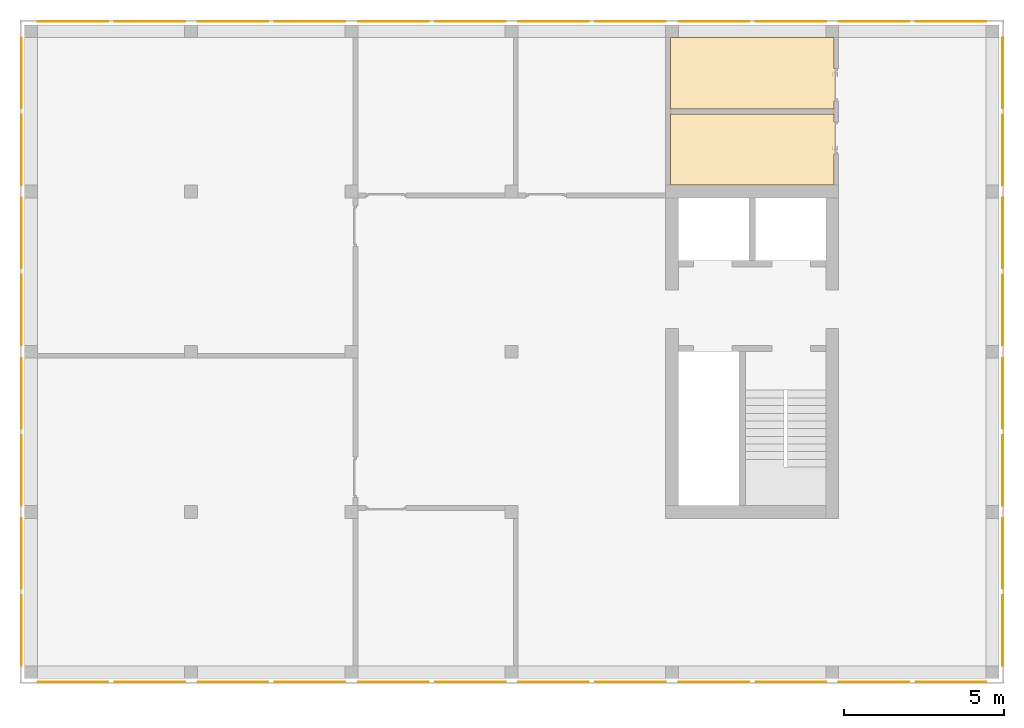
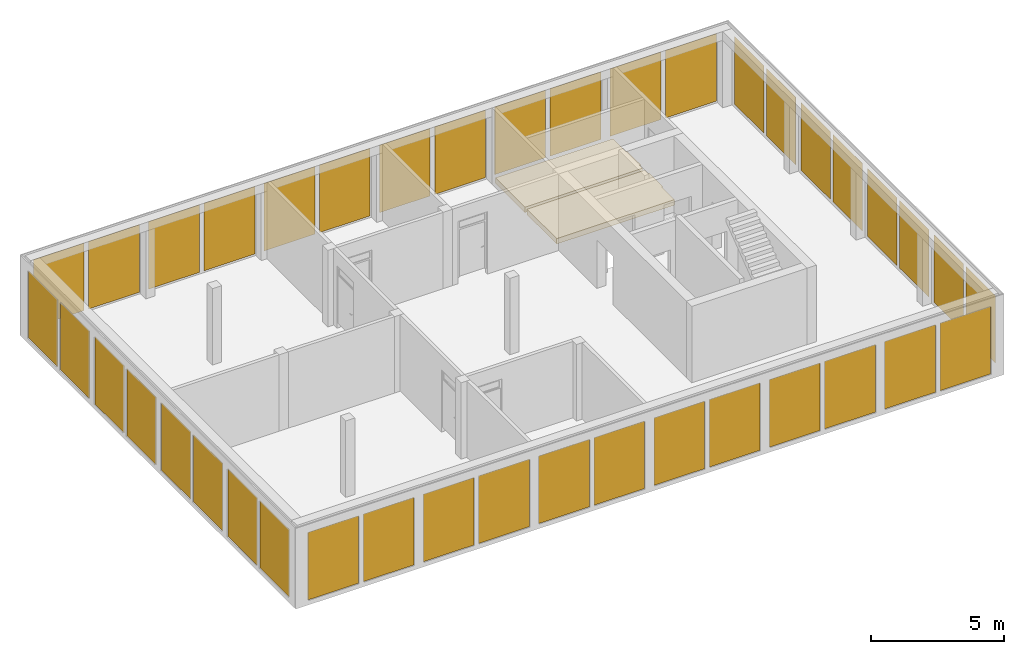
# One storey, part 5 of 6: 40 curtain walls, 2 coverings.
"""IFC2X3 building model written with IfcOpenShell, lengths in metres."""

from ifc_helpers import new_model, entity, si_unit, converted_unit, frame, frame_2d, origin, place, context, subcontext, project, spatial, rectangle, extrude, faceted_brep, material, layer, layer_set, layer_usage, element, save


model = new_model("IFC2X3")

# Units and contexts
model_context = context("Model", 3, precision=1e-05, world=origin())
body_context = subcontext(model_context, "Body", "Model", "MODEL_VIEW")
ifc_project = project(units=[si_unit("LENGTHUNIT", "METRE"), si_unit("AREAUNIT", "SQUARE_METRE"), si_unit("VOLUMEUNIT", "CUBIC_METRE"), si_unit("MASSUNIT", "GRAM", prefix="KILO"), converted_unit("PLANEANGLEUNIT", "DEGREE", entity("IfcPlaneAngleMeasure", 0.0174532925199433), si_unit("PLANEANGLEUNIT", "RADIAN"), dimensions=[0, 0, 0, 0, 0, 0, 0])], contexts=[model_context])

# Site, building, storey
site_placement = place(None, origin())
site = spatial("IfcSite", under=ifc_project, at=site_placement, CompositionType="ELEMENT")
building_placement = place(site_placement, origin())
building = spatial("IfcBuilding", under=site, at=building_placement, CompositionType="ELEMENT")
storey_placement = place(building_placement, frame((0.0, 0.0, 8.6)))
storey = spatial("IfcBuildingStorey", under=building, at=storey_placement, Name="2. Obergeschoss", CompositionType="ELEMENT", Elevation=8.6)

# Curtain walls
ifc_material_1 = material(Name="VSG")
curtain_wall_1_placement = place(storey_placement, frame((30.5106692939828, 0.400000000000018, 0.0)))
element("IfcCurtainWall", 1, at=curtain_wall_1_placement, inside=storey, material=ifc_material_1, Name="standard", context=body_context, shape_type="Brep", body=[
    faceted_brep([(0.0, 0.0, 0.0), (0.0, 0.0, 3.1), (0.005, 0.0, 3.1), (0.005, 0.0, 0.0), (0.005, 2.2, 3.1), (0.005, 2.2, 0.0), (0.0, 2.2, 3.1), (0.0, 2.2, 0.0)], [[[0, 1, 2, 3]], [[3, 2, 4, 5]], [[5, 4, 6, 7]], [[7, 6, 1, 0]], [[6, 4, 2, 1]], [[0, 3, 5, 7]]], orient=[[False], [False], [False], [False], [False], [False]]),
])
ifc_material_2 = material(Name="VSG")
curtain_wall_2_placement = place(storey_placement, frame((-0.0943307060172242, 17.8, 0.0)))
element("IfcCurtainWall", 2, at=curtain_wall_2_placement, inside=storey, material=ifc_material_2, Name="standard", context=body_context, shape_type="Brep", body=[
    faceted_brep([(0.005, -3.63797880709171e-15, 0.0), (0.0, -3.63797880709171e-15, 0.0), (0.0, -3.63797880709171e-15, 3.1), (0.005, -3.63797880709171e-15, 3.1), (0.0, 2.2, 0.0), (0.0, 2.2, 3.1), (0.005, 2.2, 0.0), (0.005, 2.2, 3.1)], [[[0, 1, 2, 3]], [[1, 4, 5, 2]], [[4, 6, 7, 5]], [[6, 0, 3, 7]], [[7, 3, 2, 5]], [[0, 6, 4, 1]]], orient=[[False], [False], [False], [False], [False], [False]]),
])
ifc_material_3 = material(Name="VSG")
curtain_wall_3_placement = place(storey_placement, frame((-0.0943307060172219, 15.4, 0.0)))
element("IfcCurtainWall", 3, at=curtain_wall_3_placement, inside=storey, material=ifc_material_3, Name="standard", context=body_context, shape_type="Brep", body=[
    faceted_brep([(0.005, -1.81898940354586e-15, 0.0), (0.0, -1.81898940354586e-15, 0.0), (0.0, -1.81898940354586e-15, 3.1), (0.005, -1.81898940354586e-15, 3.1), (0.0, 2.2, 0.0), (0.0, 2.2, 3.1), (0.005, 2.2, 0.0), (0.005, 2.2, 3.1)], [[[0, 1, 2, 3]], [[1, 4, 5, 2]], [[4, 6, 7, 5]], [[6, 0, 3, 7]], [[7, 3, 2, 5]], [[0, 6, 4, 1]]], orient=[[False], [False], [False], [False], [False], [False]]),
])
ifc_material_4 = material(Name="VSG")
curtain_wall_4_placement = place(storey_placement, frame((-0.0943307060172236, 12.8, 0.0)))
element("IfcCurtainWall", 4, at=curtain_wall_4_placement, inside=storey, material=ifc_material_4, Name="standard", context=body_context, shape_type="Brep", body=[
    faceted_brep([(0.005, 0.0, 0.0), (0.0, 0.0, 0.0), (0.0, 0.0, 3.1), (0.005, 0.0, 3.1), (0.0, 2.2, 0.0), (0.0, 2.2, 3.1), (0.005, 2.2, 0.0), (0.005, 2.2, 3.1)], [[[0, 1, 2, 3]], [[1, 4, 5, 2]], [[4, 6, 7, 5]], [[6, 0, 3, 7]], [[7, 3, 2, 5]], [[0, 6, 4, 1]]], orient=[[False], [False], [False], [False], [False], [False]]),
])
ifc_material_5 = material(Name="VSG")
curtain_wall_5_placement = place(storey_placement, frame((-0.0943307060172219, 10.4, 0.0)))
element("IfcCurtainWall", 5, at=curtain_wall_5_placement, inside=storey, material=ifc_material_5, Name="standard", context=body_context, shape_type="Brep", body=[
    faceted_brep([(0.005, 0.0, 0.0), (0.0, 0.0, 0.0), (0.0, 0.0, 3.1), (0.005, 0.0, 3.1), (0.0, 2.2, 0.0), (0.0, 2.2, 3.1), (0.005, 2.2, 0.0), (0.005, 2.2, 3.1)], [[[0, 1, 2, 3]], [[1, 4, 5, 2]], [[4, 6, 7, 5]], [[6, 0, 3, 7]], [[7, 3, 2, 5]], [[0, 6, 4, 1]]], orient=[[False], [False], [False], [False], [False], [False]]),
])
ifc_material_6 = material(Name="VSG")
curtain_wall_6_placement = place(storey_placement, frame((-0.0943307060172231, 7.80000000000001, 0.0)))
element("IfcCurtainWall", 6, at=curtain_wall_6_placement, inside=storey, material=ifc_material_6, Name="standard", context=body_context, shape_type="Brep", body=[
    faceted_brep([(0.005, 0.0, 0.0), (0.0, 0.0, 0.0), (0.0, 0.0, 3.1), (0.005, 0.0, 3.1), (0.0, 2.2, 0.0), (0.0, 2.2, 3.1), (0.005, 2.2, 0.0), (0.005, 2.2, 3.1)], [[[0, 1, 2, 3]], [[1, 4, 5, 2]], [[4, 6, 7, 5]], [[6, 0, 3, 7]], [[7, 3, 2, 5]], [[0, 6, 4, 1]]], orient=[[False], [False], [False], [False], [False], [False]]),
])
ifc_material_7 = material(Name="VSG")
curtain_wall_7_placement = place(storey_placement, frame((-0.0943307060172219, 5.40000000000002, 0.0)))
element("IfcCurtainWall", 7, at=curtain_wall_7_placement, inside=storey, material=ifc_material_7, Name="standard", context=body_context, shape_type="Brep", body=[
    faceted_brep([(0.005, 0.0, 0.0), (0.0, 0.0, 0.0), (0.0, 0.0, 3.1), (0.005, 0.0, 3.1), (0.0, 2.2, 0.0), (0.0, 2.2, 3.1), (0.005, 2.2, 0.0), (0.005, 2.2, 3.1)], [[[0, 1, 2, 3]], [[1, 4, 5, 2]], [[4, 6, 7, 5]], [[6, 0, 3, 7]], [[7, 3, 2, 5]], [[0, 6, 4, 1]]], orient=[[False], [False], [False], [False], [False], [False]]),
])
ifc_material_8 = material(Name="VSG")
curtain_wall_8_placement = place(storey_placement, frame((-0.0943307060172225, 2.80000000000001, 0.0)))
element("IfcCurtainWall", 8, at=curtain_wall_8_placement, inside=storey, material=ifc_material_8, Name="standard", context=body_context, shape_type="Brep", body=[
    faceted_brep([(0.005, 0.0, 0.0), (0.0, 0.0, 0.0), (0.0, 0.0, 3.1), (0.005, 0.0, 3.1), (0.0, 2.2, 0.0), (0.0, 2.2, 3.1), (0.005, 2.2, 0.0), (0.005, 2.2, 3.1)], [[[0, 1, 2, 3]], [[1, 4, 5, 2]], [[4, 6, 7, 5]], [[6, 0, 3, 7]], [[7, 3, 2, 5]], [[0, 6, 4, 1]]], orient=[[False], [False], [False], [False], [False], [False]]),
])
ifc_material_9 = material(Name="VSG")
curtain_wall_9_placement = place(storey_placement, frame((-0.0943307060172219, 0.400000000000018, 0.0)))
element("IfcCurtainWall", 9, at=curtain_wall_9_placement, inside=storey, material=ifc_material_9, Name="standard", context=body_context, shape_type="Brep", body=[
    faceted_brep([(0.005, 0.0, 0.0), (0.0, 0.0, 0.0), (0.0, 0.0, 3.1), (0.005, 0.0, 3.1), (0.0, 2.2, 0.0), (0.0, 2.2, 3.1), (0.005, 2.2, 0.0), (0.005, 2.2, 3.1)], [[[0, 1, 2, 3]], [[1, 4, 5, 2]], [[4, 6, 7, 5]], [[6, 0, 3, 7]], [[7, 3, 2, 5]], [[0, 6, 4, 1]]], orient=[[False], [False], [False], [False], [False], [False]]),
])
ifc_material_10 = material(Name="VSG")
curtain_wall_10_placement = place(storey_placement, frame((0.410669293982781, -0.105, 0.0)))
element("IfcCurtainWall", 10, at=curtain_wall_10_placement, inside=storey, material=ifc_material_10, Name="standard", context=body_context, shape_type="Brep", body=[
    faceted_brep([(2.2, 0.00500000000000001, 0.0), (2.2, 1.4210854715202e-17, 0.0), (2.2, 1.4210854715202e-17, 3.1), (2.2, 0.00500000000000001, 3.1), (0.0, 2.8421709430404e-16, 0.0), (0.0, 2.8421709430404e-16, 3.1), (0.0, 0.00500000000000028, 0.0), (0.0, 0.00500000000000028, 3.1)], [[[0, 1, 2, 3]], [[1, 4, 5, 2]], [[4, 6, 7, 5]], [[6, 0, 3, 7]], [[7, 3, 2, 5]], [[0, 6, 4, 1]]], orient=[[False], [False], [False], [False], [False], [False]]),
])
ifc_material_11 = material(Name="VSG")
curtain_wall_11_placement = place(storey_placement, frame((2.81066929398278, -0.105, 0.0)))
element("IfcCurtainWall", 11, at=curtain_wall_11_placement, inside=storey, material=ifc_material_11, Name="standard", context=body_context, shape_type="Brep", body=[
    faceted_brep([(2.2, 0.00500000000000001, 0.0), (2.2, 1.4210854715202e-17, 0.0), (2.2, 1.4210854715202e-17, 3.1), (2.2, 0.00500000000000001, 3.1), (0.0, 2.8421709430404e-16, 0.0), (0.0, 2.8421709430404e-16, 3.1), (0.0, 0.00500000000000028, 0.0), (0.0, 0.00500000000000028, 3.1)], [[[0, 1, 2, 3]], [[1, 4, 5, 2]], [[4, 6, 7, 5]], [[6, 0, 3, 7]], [[7, 3, 2, 5]], [[0, 6, 4, 1]]], orient=[[False], [False], [False], [False], [False], [False]]),
])
ifc_material_12 = material(Name="VSG")
curtain_wall_12_placement = place(storey_placement, frame((5.41066929398277, -0.105, 0.0)))
element("IfcCurtainWall", 12, at=curtain_wall_12_placement, inside=storey, material=ifc_material_12, Name="standard", context=body_context, shape_type="Brep", body=[
    faceted_brep([(2.2, 0.00500000000000001, 0.0), (2.2, 1.4210854715202e-17, 0.0), (2.2, 1.4210854715202e-17, 3.1), (2.2, 0.00500000000000001, 3.1), (0.0, 2.8421709430404e-16, 0.0), (0.0, 2.8421709430404e-16, 3.1), (0.0, 0.00500000000000028, 0.0), (0.0, 0.00500000000000028, 3.1)], [[[0, 1, 2, 3]], [[1, 4, 5, 2]], [[4, 6, 7, 5]], [[6, 0, 3, 7]], [[7, 3, 2, 5]], [[0, 6, 4, 1]]], orient=[[False], [False], [False], [False], [False], [False]]),
])
ifc_material_13 = material(Name="VSG")
curtain_wall_13_placement = place(storey_placement, frame((7.81066929398278, -0.105, 0.0)))
element("IfcCurtainWall", 13, at=curtain_wall_13_placement, inside=storey, material=ifc_material_13, Name="standard", context=body_context, shape_type="Brep", body=[
    faceted_brep([(2.2, 0.00500000000000001, 0.0), (2.2, 1.4210854715202e-17, 0.0), (2.2, 1.4210854715202e-17, 3.1), (2.2, 0.00500000000000001, 3.1), (0.0, 2.8421709430404e-16, 0.0), (0.0, 2.8421709430404e-16, 3.1), (0.0, 0.00500000000000028, 0.0), (0.0, 0.00500000000000028, 3.1)], [[[0, 1, 2, 3]], [[1, 4, 5, 2]], [[4, 6, 7, 5]], [[6, 0, 3, 7]], [[7, 3, 2, 5]], [[0, 6, 4, 1]]], orient=[[False], [False], [False], [False], [False], [False]]),
])
ifc_material_14 = material(Name="VSG")
curtain_wall_14_placement = place(storey_placement, frame((10.4106692939828, -0.105, 0.0)))
element("IfcCurtainWall", 14, at=curtain_wall_14_placement, inside=storey, material=ifc_material_14, Name="standard", context=body_context, shape_type="Brep", body=[
    faceted_brep([(2.2, 0.00500000000000001, 0.0), (2.2, 1.4210854715202e-17, 0.0), (2.2, 1.4210854715202e-17, 3.1), (2.2, 0.00500000000000001, 3.1), (0.0, 2.8421709430404e-16, 0.0), (0.0, 2.8421709430404e-16, 3.1), (0.0, 0.00500000000000028, 0.0), (0.0, 0.00500000000000028, 3.1)], [[[0, 1, 2, 3]], [[1, 4, 5, 2]], [[4, 6, 7, 5]], [[6, 0, 3, 7]], [[7, 3, 2, 5]], [[0, 6, 4, 1]]], orient=[[False], [False], [False], [False], [False], [False]]),
])
ifc_material_15 = material(Name="VSG")
curtain_wall_15_placement = place(storey_placement, frame((12.8106692939828, -0.105, 0.0)))
element("IfcCurtainWall", 15, at=curtain_wall_15_placement, inside=storey, material=ifc_material_15, Name="standard", context=body_context, shape_type="Brep", body=[
    faceted_brep([(2.2, 0.00500000000000001, 0.0), (2.2, 1.4210854715202e-17, 0.0), (2.2, 1.4210854715202e-17, 3.1), (2.2, 0.00500000000000001, 3.1), (0.0, 2.8421709430404e-16, 0.0), (0.0, 2.8421709430404e-16, 3.1), (0.0, 0.00500000000000028, 0.0), (0.0, 0.00500000000000028, 3.1)], [[[0, 1, 2, 3]], [[1, 4, 5, 2]], [[4, 6, 7, 5]], [[6, 0, 3, 7]], [[7, 3, 2, 5]], [[0, 6, 4, 1]]], orient=[[False], [False], [False], [False], [False], [False]]),
])
ifc_material_16 = material(Name="VSG")
curtain_wall_16_placement = place(storey_placement, frame((15.4106692939828, -0.105, 0.0)))
element("IfcCurtainWall", 16, at=curtain_wall_16_placement, inside=storey, material=ifc_material_16, Name="standard", context=body_context, shape_type="Brep", body=[
    faceted_brep([(2.20000000000001, 0.00500000000000001, 0.0), (2.20000000000001, 1.4210854715202e-17, 0.0), (2.20000000000001, 1.4210854715202e-17, 3.1), (2.20000000000001, 0.00500000000000001, 3.1), (1.81898940354586e-15, 2.8421709430404e-16, 0.0), (1.81898940354586e-15, 2.8421709430404e-16, 3.1), (1.81898940354586e-15, 0.00500000000000028, 0.0), (1.81898940354586e-15, 0.00500000000000028, 3.1)], [[[0, 1, 2, 3]], [[1, 4, 5, 2]], [[4, 6, 7, 5]], [[6, 0, 3, 7]], [[7, 3, 2, 5]], [[0, 6, 4, 1]]], orient=[[False], [False], [False], [False], [False], [False]]),
])
ifc_material_17 = material(Name="VSG")
curtain_wall_17_placement = place(storey_placement, frame((17.8106692939828, -0.105, 0.0)))
element("IfcCurtainWall", 17, at=curtain_wall_17_placement, inside=storey, material=ifc_material_17, Name="standard", context=body_context, shape_type="Brep", body=[
    faceted_brep([(2.2, 0.00500000000000001, 0.0), (2.2, 1.4210854715202e-17, 0.0), (2.2, 1.4210854715202e-17, 3.1), (2.2, 0.00500000000000001, 3.1), (0.0, 2.8421709430404e-16, 0.0), (0.0, 2.8421709430404e-16, 3.1), (0.0, 0.00500000000000028, 0.0), (0.0, 0.00500000000000028, 3.1)], [[[0, 1, 2, 3]], [[1, 4, 5, 2]], [[4, 6, 7, 5]], [[6, 0, 3, 7]], [[7, 3, 2, 5]], [[0, 6, 4, 1]]], orient=[[False], [False], [False], [False], [False], [False]]),
])
ifc_material_18 = material(Name="VSG")
curtain_wall_18_placement = place(storey_placement, frame((20.4106692939828, -0.105000000000001, 0.0)))
element("IfcCurtainWall", 18, at=curtain_wall_18_placement, inside=storey, material=ifc_material_18, Name="standard", context=body_context, shape_type="Brep", body=[
    faceted_brep([(2.2, 0.00500000000000001, 0.0), (2.2, 1.4210854715202e-17, 0.0), (2.2, 1.4210854715202e-17, 3.1), (2.2, 0.00500000000000001, 3.1), (0.0, 2.8421709430404e-16, 0.0), (0.0, 2.8421709430404e-16, 3.1), (0.0, 0.00500000000000028, 0.0), (0.0, 0.00500000000000028, 3.1)], [[[0, 1, 2, 3]], [[1, 4, 5, 2]], [[4, 6, 7, 5]], [[6, 0, 3, 7]], [[7, 3, 2, 5]], [[0, 6, 4, 1]]], orient=[[False], [False], [False], [False], [False], [False]]),
])
ifc_material_19 = material(Name="VSG")
curtain_wall_19_placement = place(storey_placement, frame((22.8106692939828, -0.105, 0.0)))
element("IfcCurtainWall", 19, at=curtain_wall_19_placement, inside=storey, material=ifc_material_19, Name="standard", context=body_context, shape_type="Brep", body=[
    faceted_brep([(2.2, 0.00500000000000001, 0.0), (2.2, 1.4210854715202e-17, 0.0), (2.2, 1.4210854715202e-17, 3.1), (2.2, 0.00500000000000001, 3.1), (0.0, 2.8421709430404e-16, 0.0), (0.0, 2.8421709430404e-16, 3.1), (0.0, 0.00500000000000028, 0.0), (0.0, 0.00500000000000028, 3.1)], [[[0, 1, 2, 3]], [[1, 4, 5, 2]], [[4, 6, 7, 5]], [[6, 0, 3, 7]], [[7, 3, 2, 5]], [[0, 6, 4, 1]]], orient=[[False], [False], [False], [False], [False], [False]]),
])
ifc_material_20 = material(Name="VSG")
curtain_wall_20_placement = place(storey_placement, frame((25.4106692939828, -0.105000000000001, 0.0)))
element("IfcCurtainWall", 20, at=curtain_wall_20_placement, inside=storey, material=ifc_material_20, Name="standard", context=body_context, shape_type="Brep", body=[
    faceted_brep([(2.2, 0.00500000000000001, 0.0), (2.2, 1.4210854715202e-17, 0.0), (2.2, 1.4210854715202e-17, 3.1), (2.2, 0.00500000000000001, 3.1), (0.0, 2.8421709430404e-16, 0.0), (0.0, 2.8421709430404e-16, 3.1), (0.0, 0.00500000000000028, 0.0), (0.0, 0.00500000000000028, 3.1)], [[[0, 1, 2, 3]], [[1, 4, 5, 2]], [[4, 6, 7, 5]], [[6, 0, 3, 7]], [[7, 3, 2, 5]], [[0, 6, 4, 1]]], orient=[[False], [False], [False], [False], [False], [False]]),
])
ifc_material_21 = material(Name="VSG")
curtain_wall_21_placement = place(storey_placement, frame((27.8106692939828, -0.105, 0.0)))
element("IfcCurtainWall", 21, at=curtain_wall_21_placement, inside=storey, material=ifc_material_21, Name="standard", context=body_context, shape_type="Brep", body=[
    faceted_brep([(2.2, 0.00500000000000001, 0.0), (2.2, 1.4210854715202e-17, 0.0), (2.2, 1.4210854715202e-17, 3.1), (2.2, 0.00500000000000001, 3.1), (0.0, 2.8421709430404e-16, 0.0), (0.0, 2.8421709430404e-16, 3.1), (0.0, 0.00500000000000028, 0.0), (0.0, 0.00500000000000028, 3.1)], [[[0, 1, 2, 3]], [[1, 4, 5, 2]], [[4, 6, 7, 5]], [[6, 0, 3, 7]], [[7, 3, 2, 5]], [[0, 6, 4, 1]]], orient=[[False], [False], [False], [False], [False], [False]]),
])
ifc_material_22 = material(Name="VSG")
curtain_wall_22_placement = place(storey_placement, frame((0.410669293982781, 20.5, 0.0)))
element("IfcCurtainWall", 22, at=curtain_wall_22_placement, inside=storey, material=ifc_material_22, Name="standard", context=body_context, shape_type="Brep", body=[
    faceted_brep([(2.2, 0.0, 0.0), (2.2, 0.0, 3.1), (2.2, 0.005, 3.1), (2.2, 0.005, 0.0), (0.0, 0.005, 3.1), (0.0, 0.005, 0.0), (0.0, 0.0, 3.1), (0.0, 0.0, 0.0)], [[[0, 1, 2, 3]], [[3, 2, 4, 5]], [[5, 4, 6, 7]], [[7, 6, 1, 0]], [[6, 4, 2, 1]], [[0, 3, 5, 7]]], orient=[[False], [False], [False], [False], [False], [False]]),
])
ifc_material_23 = material(Name="VSG")
curtain_wall_23_placement = place(storey_placement, frame((2.81066929398278, 20.5, 0.0)))
element("IfcCurtainWall", 23, at=curtain_wall_23_placement, inside=storey, material=ifc_material_23, Name="standard", context=body_context, shape_type="Brep", body=[
    faceted_brep([(2.2, 0.0, 0.0), (2.2, 0.0, 3.1), (2.2, 0.005, 3.1), (2.2, 0.005, 0.0), (0.0, 0.005, 3.1), (0.0, 0.005, 0.0), (0.0, 0.0, 3.1), (0.0, 0.0, 0.0)], [[[0, 1, 2, 3]], [[3, 2, 4, 5]], [[5, 4, 6, 7]], [[7, 6, 1, 0]], [[6, 4, 2, 1]], [[0, 3, 5, 7]]], orient=[[False], [False], [False], [False], [False], [False]]),
])
ifc_material_24 = material(Name="VSG")
curtain_wall_24_placement = place(storey_placement, frame((5.41066929398277, 20.5, 0.0)))
element("IfcCurtainWall", 24, at=curtain_wall_24_placement, inside=storey, material=ifc_material_24, Name="standard", context=body_context, shape_type="Brep", body=[
    faceted_brep([(2.2, 0.0, 0.0), (2.2, 0.0, 3.1), (2.2, 0.005, 3.1), (2.2, 0.005, 0.0), (0.0, 0.005, 3.1), (0.0, 0.005, 0.0), (0.0, 0.0, 3.1), (0.0, 0.0, 0.0)], [[[0, 1, 2, 3]], [[3, 2, 4, 5]], [[5, 4, 6, 7]], [[7, 6, 1, 0]], [[6, 4, 2, 1]], [[0, 3, 5, 7]]], orient=[[False], [False], [False], [False], [False], [False]]),
])
ifc_material_25 = material(Name="VSG")
curtain_wall_25_placement = place(storey_placement, frame((7.81066929398278, 20.5, 0.0)))
element("IfcCurtainWall", 25, at=curtain_wall_25_placement, inside=storey, material=ifc_material_25, Name="standard", context=body_context, shape_type="Brep", body=[
    faceted_brep([(2.2, 0.0, 0.0), (2.2, 0.0, 3.1), (2.2, 0.005, 3.1), (2.2, 0.005, 0.0), (0.0, 0.005, 3.1), (0.0, 0.005, 0.0), (0.0, 0.0, 3.1), (0.0, 0.0, 0.0)], [[[0, 1, 2, 3]], [[3, 2, 4, 5]], [[5, 4, 6, 7]], [[7, 6, 1, 0]], [[6, 4, 2, 1]], [[0, 3, 5, 7]]], orient=[[False], [False], [False], [False], [False], [False]]),
])
ifc_material_26 = material(Name="VSG")
curtain_wall_26_placement = place(storey_placement, frame((10.4106692939828, 20.5, 0.0)))
element("IfcCurtainWall", 26, at=curtain_wall_26_placement, inside=storey, material=ifc_material_26, Name="standard", context=body_context, shape_type="Brep", body=[
    faceted_brep([(2.2, 0.0, 0.0), (2.2, 0.0, 3.1), (2.2, 0.005, 3.1), (2.2, 0.005, 0.0), (0.0, 0.005, 3.1), (0.0, 0.005, 0.0), (0.0, 0.0, 3.1), (0.0, 0.0, 0.0)], [[[0, 1, 2, 3]], [[3, 2, 4, 5]], [[5, 4, 6, 7]], [[7, 6, 1, 0]], [[6, 4, 2, 1]], [[0, 3, 5, 7]]], orient=[[False], [False], [False], [False], [False], [False]]),
])
ifc_material_27 = material(Name="VSG")
curtain_wall_27_placement = place(storey_placement, frame((12.8106692939828, 20.5, 0.0)))
element("IfcCurtainWall", 27, at=curtain_wall_27_placement, inside=storey, material=ifc_material_27, Name="standard", context=body_context, shape_type="Brep", body=[
    faceted_brep([(2.2, 0.0, 0.0), (2.2, 0.0, 3.1), (2.2, 0.005, 3.1), (2.2, 0.005, 0.0), (0.0, 0.005, 3.1), (0.0, 0.005, 0.0), (0.0, 0.0, 3.1), (0.0, 0.0, 0.0)], [[[0, 1, 2, 3]], [[3, 2, 4, 5]], [[5, 4, 6, 7]], [[7, 6, 1, 0]], [[6, 4, 2, 1]], [[0, 3, 5, 7]]], orient=[[False], [False], [False], [False], [False], [False]]),
])
ifc_material_28 = material(Name="VSG")
curtain_wall_28_placement = place(storey_placement, frame((15.4106692939828, 20.5, 0.0)))
element("IfcCurtainWall", 28, at=curtain_wall_28_placement, inside=storey, material=ifc_material_28, Name="standard", context=body_context, shape_type="Brep", body=[
    faceted_brep([(2.20000000000001, 0.0, 0.0), (2.20000000000001, 0.0, 3.1), (2.20000000000001, 0.005, 3.1), (2.20000000000001, 0.005, 0.0), (1.81898940354586e-15, 0.005, 3.1), (1.81898940354586e-15, 0.005, 0.0), (1.81898940354586e-15, 0.0, 3.1), (1.81898940354586e-15, 0.0, 0.0)], [[[0, 1, 2, 3]], [[3, 2, 4, 5]], [[5, 4, 6, 7]], [[7, 6, 1, 0]], [[6, 4, 2, 1]], [[0, 3, 5, 7]]], orient=[[False], [False], [False], [False], [False], [False]]),
])
ifc_material_29 = material(Name="VSG")
curtain_wall_29_placement = place(storey_placement, frame((17.8106692939828, 20.5, 0.0)))
element("IfcCurtainWall", 29, at=curtain_wall_29_placement, inside=storey, material=ifc_material_29, Name="standard", context=body_context, shape_type="Brep", body=[
    faceted_brep([(2.2, 0.0, 0.0), (2.2, 0.0, 3.1), (2.2, 0.005, 3.1), (2.2, 0.005, 0.0), (0.0, 0.005, 3.1), (0.0, 0.005, 0.0), (0.0, 0.0, 3.1), (0.0, 0.0, 0.0)], [[[0, 1, 2, 3]], [[3, 2, 4, 5]], [[5, 4, 6, 7]], [[7, 6, 1, 0]], [[6, 4, 2, 1]], [[0, 3, 5, 7]]], orient=[[False], [False], [False], [False], [False], [False]]),
])
ifc_material_30 = material(Name="VSG")
curtain_wall_30_placement = place(storey_placement, frame((20.4106692939828, 20.5, 0.0)))
element("IfcCurtainWall", 30, at=curtain_wall_30_placement, inside=storey, material=ifc_material_30, Name="standard", context=body_context, shape_type="Brep", body=[
    faceted_brep([(2.2, 0.0, 0.0), (2.2, 0.0, 3.1), (2.2, 0.005, 3.1), (2.2, 0.005, 0.0), (0.0, 0.005, 3.1), (0.0, 0.005, 0.0), (0.0, 0.0, 3.1), (0.0, 0.0, 0.0)], [[[0, 1, 2, 3]], [[3, 2, 4, 5]], [[5, 4, 6, 7]], [[7, 6, 1, 0]], [[6, 4, 2, 1]], [[0, 3, 5, 7]]], orient=[[False], [False], [False], [False], [False], [False]]),
])
ifc_material_31 = material(Name="VSG")
curtain_wall_31_placement = place(storey_placement, frame((22.8106692939828, 20.5, 0.0)))
element("IfcCurtainWall", 31, at=curtain_wall_31_placement, inside=storey, material=ifc_material_31, Name="standard", context=body_context, shape_type="Brep", body=[
    faceted_brep([(2.2, 0.0, 0.0), (2.2, 0.0, 3.1), (2.2, 0.005, 3.1), (2.2, 0.005, 0.0), (0.0, 0.005, 3.1), (0.0, 0.005, 0.0), (0.0, 0.0, 3.1), (0.0, 0.0, 0.0)], [[[0, 1, 2, 3]], [[3, 2, 4, 5]], [[5, 4, 6, 7]], [[7, 6, 1, 0]], [[6, 4, 2, 1]], [[0, 3, 5, 7]]], orient=[[False], [False], [False], [False], [False], [False]]),
])
ifc_material_32 = material(Name="VSG")
curtain_wall_32_placement = place(storey_placement, frame((25.4106692939828, 20.5, 0.0)))
element("IfcCurtainWall", 32, at=curtain_wall_32_placement, inside=storey, material=ifc_material_32, Name="standard", context=body_context, shape_type="Brep", body=[
    faceted_brep([(2.2, 0.0, 0.0), (2.2, 0.0, 3.1), (2.2, 0.005, 3.1), (2.2, 0.005, 0.0), (0.0, 0.005, 3.1), (0.0, 0.005, 0.0), (0.0, 0.0, 3.1), (0.0, 0.0, 0.0)], [[[0, 1, 2, 3]], [[3, 2, 4, 5]], [[5, 4, 6, 7]], [[7, 6, 1, 0]], [[6, 4, 2, 1]], [[0, 3, 5, 7]]], orient=[[False], [False], [False], [False], [False], [False]]),
])
ifc_material_33 = material(Name="VSG")
curtain_wall_33_placement = place(storey_placement, frame((27.8106692939828, 20.5, 0.0)))
element("IfcCurtainWall", 33, at=curtain_wall_33_placement, inside=storey, material=ifc_material_33, Name="standard", context=body_context, shape_type="Brep", body=[
    faceted_brep([(2.2, 0.0, 0.0), (2.2, 0.0, 3.1), (2.2, 0.005, 3.1), (2.2, 0.005, 0.0), (0.0, 0.005, 3.1), (0.0, 0.005, 0.0), (0.0, 0.0, 3.1), (0.0, 0.0, 0.0)], [[[0, 1, 2, 3]], [[3, 2, 4, 5]], [[5, 4, 6, 7]], [[7, 6, 1, 0]], [[6, 4, 2, 1]], [[0, 3, 5, 7]]], orient=[[False], [False], [False], [False], [False], [False]]),
])
ifc_material_34 = material(Name="VSG")
curtain_wall_34_placement = place(storey_placement, frame((30.5106692939828, 17.8, 0.0)))
element("IfcCurtainWall", 34, at=curtain_wall_34_placement, inside=storey, material=ifc_material_34, Name="standard", context=body_context, shape_type="Brep", body=[
    faceted_brep([(0.0, -3.63797880709171e-15, 0.0), (0.0, -3.63797880709171e-15, 3.1), (0.005, -3.63797880709171e-15, 3.1), (0.005, -3.63797880709171e-15, 0.0), (0.005, 2.2, 3.1), (0.005, 2.2, 0.0), (0.0, 2.2, 3.1), (0.0, 2.2, 0.0)], [[[0, 1, 2, 3]], [[3, 2, 4, 5]], [[5, 4, 6, 7]], [[7, 6, 1, 0]], [[6, 4, 2, 1]], [[0, 3, 5, 7]]], orient=[[False], [False], [False], [False], [False], [False]]),
])
ifc_material_35 = material(Name="VSG")
curtain_wall_35_placement = place(storey_placement, frame((30.5106692939828, 15.4, 0.0)))
element("IfcCurtainWall", 35, at=curtain_wall_35_placement, inside=storey, material=ifc_material_35, Name="standard", context=body_context, shape_type="Brep", body=[
    faceted_brep([(0.0, -1.81898940354586e-15, 0.0), (0.0, -1.81898940354586e-15, 3.1), (0.005, -1.81898940354586e-15, 3.1), (0.005, -1.81898940354586e-15, 0.0), (0.005, 2.2, 3.1), (0.005, 2.2, 0.0), (0.0, 2.2, 3.1), (0.0, 2.2, 0.0)], [[[0, 1, 2, 3]], [[3, 2, 4, 5]], [[5, 4, 6, 7]], [[7, 6, 1, 0]], [[6, 4, 2, 1]], [[0, 3, 5, 7]]], orient=[[False], [False], [False], [False], [False], [False]]),
])
ifc_material_36 = material(Name="VSG")
curtain_wall_36_placement = place(storey_placement, frame((30.5106692939828, 12.8, 0.0)))
element("IfcCurtainWall", 36, at=curtain_wall_36_placement, inside=storey, material=ifc_material_36, Name="standard", context=body_context, shape_type="Brep", body=[
    faceted_brep([(0.0, 0.0, 0.0), (0.0, 0.0, 3.1), (0.005, 0.0, 3.1), (0.005, 0.0, 0.0), (0.005, 2.2, 3.1), (0.005, 2.2, 0.0), (0.0, 2.2, 3.1), (0.0, 2.2, 0.0)], [[[0, 1, 2, 3]], [[3, 2, 4, 5]], [[5, 4, 6, 7]], [[7, 6, 1, 0]], [[6, 4, 2, 1]], [[0, 3, 5, 7]]], orient=[[False], [False], [False], [False], [False], [False]]),
])
ifc_material_37 = material(Name="VSG")
curtain_wall_37_placement = place(storey_placement, frame((30.5106692939828, 10.4, 0.0)))
element("IfcCurtainWall", 37, at=curtain_wall_37_placement, inside=storey, material=ifc_material_37, Name="standard", context=body_context, shape_type="Brep", body=[
    faceted_brep([(0.0, 0.0, 0.0), (0.0, 0.0, 3.1), (0.005, 0.0, 3.1), (0.005, 0.0, 0.0), (0.005, 2.2, 3.1), (0.005, 2.2, 0.0), (0.0, 2.2, 3.1), (0.0, 2.2, 0.0)], [[[0, 1, 2, 3]], [[3, 2, 4, 5]], [[5, 4, 6, 7]], [[7, 6, 1, 0]], [[6, 4, 2, 1]], [[0, 3, 5, 7]]], orient=[[False], [False], [False], [False], [False], [False]]),
])
ifc_material_38 = material(Name="VSG")
curtain_wall_38_placement = place(storey_placement, frame((30.5106692939828, 7.80000000000001, 0.0)))
element("IfcCurtainWall", 38, at=curtain_wall_38_placement, inside=storey, material=ifc_material_38, Name="standard", context=body_context, shape_type="Brep", body=[
    faceted_brep([(0.0, 0.0, 0.0), (0.0, 0.0, 3.1), (0.005, 0.0, 3.1), (0.005, 0.0, 0.0), (0.005, 2.2, 3.1), (0.005, 2.2, 0.0), (0.0, 2.2, 3.1), (0.0, 2.2, 0.0)], [[[0, 1, 2, 3]], [[3, 2, 4, 5]], [[5, 4, 6, 7]], [[7, 6, 1, 0]], [[6, 4, 2, 1]], [[0, 3, 5, 7]]], orient=[[False], [False], [False], [False], [False], [False]]),
])
ifc_material_39 = material(Name="VSG")
curtain_wall_39_placement = place(storey_placement, frame((30.5106692939828, 5.40000000000002, 0.0)))
element("IfcCurtainWall", 39, at=curtain_wall_39_placement, inside=storey, material=ifc_material_39, Name="standard", context=body_context, shape_type="Brep", body=[
    faceted_brep([(0.0, 0.0, 0.0), (0.0, 0.0, 3.1), (0.005, 0.0, 3.1), (0.005, 0.0, 0.0), (0.005, 2.2, 3.1), (0.005, 2.2, 0.0), (0.0, 2.2, 3.1), (0.0, 2.2, 0.0)], [[[0, 1, 2, 3]], [[3, 2, 4, 5]], [[5, 4, 6, 7]], [[7, 6, 1, 0]], [[6, 4, 2, 1]], [[0, 3, 5, 7]]], orient=[[False], [False], [False], [False], [False], [False]]),
])
ifc_material_40 = material(Name="VSG")
curtain_wall_40_placement = place(storey_placement, frame((30.5106692939828, 2.80000000000001, 0.0)))
element("IfcCurtainWall", 40, at=curtain_wall_40_placement, inside=storey, material=ifc_material_40, Name="standard", context=body_context, shape_type="Brep", body=[
    faceted_brep([(0.0, 0.0, 0.0), (0.0, 0.0, 3.1), (0.005, 0.0, 3.1), (0.005, 0.0, 0.0), (0.005, 2.2, 3.1), (0.005, 2.2, 0.0), (0.0, 2.2, 3.1), (0.0, 2.2, 0.0)], [[[0, 1, 2, 3]], [[3, 2, 4, 5]], [[5, 4, 6, 7]], [[7, 6, 1, 0]], [[6, 4, 2, 1]], [[0, 3, 5, 7]]], orient=[[False], [False], [False], [False], [False], [False]]),
])

# Space
space_1_placement = place(storey_placement, frame((20.15, 15.4, 0.0)))
space_1 = spatial("IfcSpace", under=storey, at=space_1_placement, CompositionType="ELEMENT")

# Covering
ifc_material_41 = material()
ifc_layer_1 = layer(ifc_material_41, 0.23)
ifc_material_42 = material()
ifc_layer_2 = layer(ifc_material_42, 0.02)
ifc_layer_set_1 = layer_set([ifc_layer_1, ifc_layer_2])
ifc_layer_usage_1 = layer_usage(ifc_layer_set_1, "AXIS3", "POSITIVE", 0.0)
covering_1_placement = place(storey_placement, frame((20.15, 15.4, 0.0)))
element("IfcCovering", 41, at=covering_1_placement, inside=space_1, material=ifc_layer_usage_1, PredefinedType="FLOORING", context=body_context, shape_type="SweptSolid", body=[
    extrude(rectangle(XDim=0.05, YDim=1.01, at=frame_2d((0.025, 0.505), x_axis=(1.0, 3.63797880709171e-14))), frame((5.1, 0.965, 0.0), z_axis=(0.0, 0.0, 1.0), x_axis=(1.0, 0.0, 0.0)), (0.0, 0.0, 1.0), 0.25),
    extrude(rectangle(XDim=2.225, YDim=5.1, at=frame_2d((2.55, -1.1125), x_axis=(0.0, -1.0))), frame((3.63797880709171e-15, 2.225, 0.0), z_axis=(0.0, 0.0, 1.0), x_axis=(1.0, 0.0, 0.0)), (0.0, 0.0, 1.0), 0.25),
])

# Space
space_2_placement = place(storey_placement, frame((20.15, 17.775, 0.0)))
space_2 = spatial("IfcSpace", under=storey, at=space_2_placement, CompositionType="ELEMENT")

# Covering
ifc_material_43 = material()
ifc_layer_3 = layer(ifc_material_43, 0.23)
ifc_material_44 = material()
ifc_layer_4 = layer(ifc_material_44, 0.02)
ifc_layer_set_2 = layer_set([ifc_layer_3, ifc_layer_4])
ifc_layer_usage_2 = layer_usage(ifc_layer_set_2, "AXIS3", "POSITIVE", 0.0)
covering_2_placement = place(storey_placement, frame((20.15, 17.775, 0.0)))
element("IfcCovering", 42, at=covering_2_placement, inside=space_2, material=ifc_layer_usage_2, PredefinedType="FLOORING", context=body_context, shape_type="SweptSolid", body=[
    extrude(rectangle(XDim=0.05, YDim=1.01, at=frame_2d((0.025, 0.505), x_axis=(1.0, 0.0))), frame((5.1, 0.25, 0.0), z_axis=(0.0, 0.0, 1.0), x_axis=(1.0, 0.0, 0.0)), (0.0, 0.0, 1.0), 0.25),
    extrude(rectangle(XDim=5.1, YDim=2.225, at=frame_2d((-2.55, -1.1125), x_axis=(-1.0, 0.0))), frame((5.1, 2.225, 0.0), z_axis=(0.0, 0.0, 1.0), x_axis=(1.0, 0.0, 0.0)), (0.0, 0.0, 1.0), 0.25),
])

save(model, "model.ifc")
